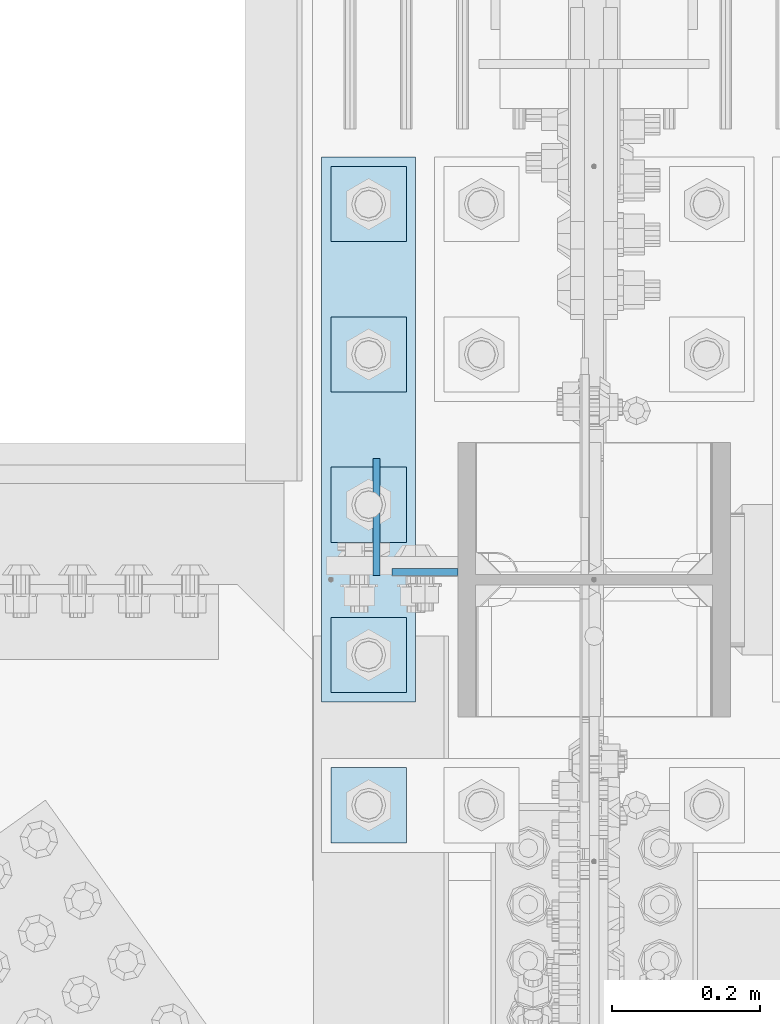
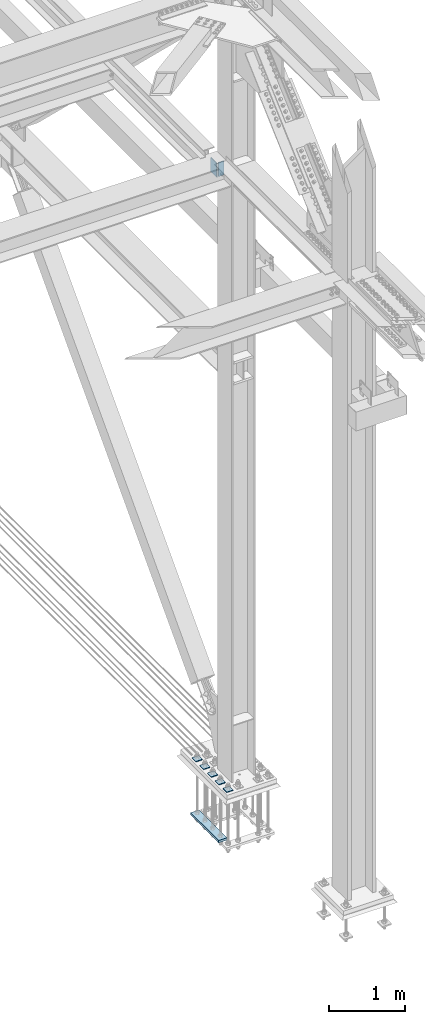
# One storey, part 3629 of 3843: 8 plates, 3 elements without a shape of their own.
"""IFC2X3 building model written with IfcOpenShell, lengths in millimetres."""

from ifc_helpers import new_model, si_unit, frame, origin_with_axes, place, context, subcontext, project, spatial, faceted_brep, material, type_object, element, aggregate, save


model = new_model("IFC2X3")

# Units and contexts
model_context = context("Model", 3, precision=1e-05, world=origin_with_axes())
body_context = subcontext(model_context, "Body", "Model", "MODEL_VIEW")
ifc_project = project(units=[si_unit("LENGTHUNIT", "METRE", prefix="MILLI"), si_unit("AREAUNIT", "SQUARE_METRE"), si_unit("VOLUMEUNIT", "CUBIC_METRE"), si_unit("MASSUNIT", "GRAM", prefix="KILO"), si_unit("TIMEUNIT", "SECOND"), si_unit("PLANEANGLEUNIT", "RADIAN"), si_unit("SOLIDANGLEUNIT", "STERADIAN"), si_unit("THERMODYNAMICTEMPERATUREUNIT", "DEGREE_CELSIUS"), si_unit("LUMINOUSINTENSITYUNIT", "LUMEN")], contexts=[model_context])

# Site, building, storey
site_placement = place(None, origin_with_axes())
site = spatial("IfcSite", under=ifc_project, at=site_placement, CompositionType="ELEMENT")
building_placement = place(site_placement, origin_with_axes())
building = spatial("IfcBuilding", under=site, at=building_placement, Name="Undefined", CompositionType="ELEMENT")
storey_placement = place(building_placement, origin_with_axes())
storey = spatial("IfcBuildingStorey", under=building, at=storey_placement, Name="Undefined", CompositionType="ELEMENT", Elevation=0.0)

# Assembly, plate
assembly_1_placement = place(storey_placement, origin_with_axes())
assembly_1 = element("IfcElementAssembly", 1, at=assembly_1_placement, inside=storey, Name="COLUMN", AssemblyPlace="NOTDEFINED", PredefinedType="RIGID_FRAME")
ifc_material = material(Name="STEEL/A572-50")
plate_type_1 = type_object("IfcPlateType", PredefinedType="NOTDEFINED")
plate_1_placement = place(assembly_1_placement, frame((85464.65, 92225.01875, 39573.2), z_axis=(-1.0, 0.0, 0.0), x_axis=(0.0, 0.0, -1.0)))
plate_1 = element("IfcPlate", 2, at=plate_1_placement, type_object=plate_type_1, material=ifc_material, Name="PLATE", context=body_context, shape_type="Brep", body=[
    faceted_brep([(0.0, -4.76249999999709, 0.0), (0.0, -4.76249999999709, 88.9000015258789), (0.0, 4.76249999999709, 88.9000015258789), (0.0, 4.76249999999709, 0.0), (228.600006102781, -4.7625000004191, 88.9000015257589), (228.600006102781, 4.76249999954598, 88.9000015257443), (228.600006103079, -4.7625000004482, 7.27595761418343e-12), (228.600006103079, 4.76249999954598, -7.27595761418343e-12)], [[[0, 1, 2, 3]], [[1, 4, 5, 2]], [[4, 6, 7, 5]], [[6, 0, 3, 7]], [[5, 7, 3, 2]], [[6, 4, 1, 0]]]),
])
aggregate(assembly_1, [plate_1])

# Assembly, plates
assembly_2_placement = place(storey_placement, origin_with_axes())
assembly_2 = element("IfcElementAssembly", 3, at=assembly_2_placement, inside=storey, Name="TEMPLATE", AssemblyPlace="NOTDEFINED", PredefinedType="RIGID_FRAME")
plate_type_2 = type_object("IfcPlateType", PredefinedType="NOTDEFINED")
plate_2_placement = place(assembly_2_placement, frame((85293.2, 91960.7, 29686.25), z_axis=(0.0, -1.0, 0.0), x_axis=(1.0, 0.0, 0.0)))
plate_2 = element("IfcPlate", 4, at=plate_2_placement, type_object=plate_type_2, material=ifc_material, Name="Washer Plate", context=body_context, shape_type="Brep", body=[
    faceted_brep([(0.0, -6.3499999046162, 0.0), (-1.67347025126219e-10, -6.35000000000582, 101.600000000151), (-1.67347025126219e-10, 6.35000000000582, 101.600000000151), (7.27595761418343e-12, 6.3499999046162, 0.0), (101.599998474121, -6.34999999999854, 101.599998474121), (101.599998474121, 6.34999999999854, 101.599998474121), (101.6, -6.34999999999854, 0.0), (101.6, 6.34999999999854, 0.0)], [[[0, 1, 2, 3]], [[1, 4, 5, 2]], [[4, 6, 7, 5]], [[6, 0, 3, 7]], [[5, 7, 3, 2]], [[6, 4, 1, 0]]]),
])
plate_3_placement = place(assembly_2_placement, frame((85293.2, 92163.9, 29686.25), z_axis=(0.0, -1.0, 0.0), x_axis=(1.0, 0.0, 0.0)))
plate_3 = element("IfcPlate", 5, at=plate_3_placement, type_object=plate_type_2, material=ifc_material, Name="Washer Plate", context=body_context, shape_type="Brep", body=[
    faceted_brep([(0.0, -6.3499999046162, 0.0), (-1.67347025126219e-10, -6.35000000000582, 101.600000000151), (-1.67347025126219e-10, 6.35000000000582, 101.600000000151), (7.27595761418343e-12, 6.3499999046162, 0.0), (101.599998474121, -6.34999999999854, 101.599998474121), (101.599998474121, 6.34999999999854, 101.599998474121), (101.6, -6.34999999999854, 0.0), (101.6, 6.34999999999854, 0.0)], [[[0, 1, 2, 3]], [[1, 4, 5, 2]], [[4, 6, 7, 5]], [[6, 0, 3, 7]], [[5, 7, 3, 2]], [[6, 4, 1, 0]]]),
])
plate_4_placement = place(assembly_2_placement, frame((85293.2, 92367.1, 29686.25), z_axis=(0.0, -1.0, 0.0), x_axis=(1.0, 0.0, 0.0)))
plate_4 = element("IfcPlate", 6, at=plate_4_placement, type_object=plate_type_2, material=ifc_material, Name="Washer Plate", context=body_context, shape_type="Brep", body=[
    faceted_brep([(0.0, -6.3499999046162, 0.0), (-1.67347025126219e-10, -6.35000000000582, 101.600000000151), (-1.67347025126219e-10, 6.35000000000582, 101.600000000151), (7.27595761418343e-12, 6.3499999046162, 0.0), (101.599998474121, -6.34999999999854, 101.599998474121), (101.599998474121, 6.34999999999854, 101.599998474121), (101.6, -6.34999999999854, 0.0), (101.6, 6.34999999999854, 0.0)], [[[0, 1, 2, 3]], [[1, 4, 5, 2]], [[4, 6, 7, 5]], [[6, 0, 3, 7]], [[5, 7, 3, 2]], [[6, 4, 1, 0]]]),
])
plate_5_placement = place(assembly_2_placement, frame((85293.2, 92570.3, 29686.25), z_axis=(0.0, -1.0, 0.0), x_axis=(1.0, 0.0, 0.0)))
plate_5 = element("IfcPlate", 7, at=plate_5_placement, type_object=plate_type_2, material=ifc_material, Name="Washer Plate", context=body_context, shape_type="Brep", body=[
    faceted_brep([(0.0, -6.3499999046162, 0.0), (-1.67347025126219e-10, -6.35000000000582, 101.600000000151), (-1.67347025126219e-10, 6.35000000000582, 101.600000000151), (7.27595761418343e-12, 6.3499999046162, 0.0), (101.599998474121, -6.34999999999854, 101.599998474121), (101.599998474121, 6.34999999999854, 101.599998474121), (101.6, -6.34999999999854, 0.0), (101.6, 6.34999999999854, 0.0)], [[[0, 1, 2, 3]], [[1, 4, 5, 2]], [[4, 6, 7, 5]], [[6, 0, 3, 7]], [[5, 7, 3, 2]], [[6, 4, 1, 0]]]),
])
plate_6_placement = place(assembly_2_placement, frame((85293.2, 92773.5, 29686.25), z_axis=(0.0, -1.0, 0.0), x_axis=(1.0, 0.0, 0.0)))
plate_6 = element("IfcPlate", 8, at=plate_6_placement, type_object=plate_type_2, material=ifc_material, Name="Washer Plate", context=body_context, shape_type="Brep", body=[
    faceted_brep([(0.0, -6.3499999046162, 0.0), (-1.67347025126219e-10, -6.35000000000582, 101.600000000151), (-1.67347025126219e-10, 6.35000000000582, 101.600000000151), (7.27595761418343e-12, 6.3499999046162, 0.0), (101.599998474121, -6.34999999999854, 101.599998474121), (101.599998474121, 6.34999999999854, 101.599998474121), (101.6, -6.34999999999854, 0.0), (101.6, 6.34999999999854, 0.0)], [[[0, 1, 2, 3]], [[1, 4, 5, 2]], [[4, 6, 7, 5]], [[6, 0, 3, 7]], [[5, 7, 3, 2]], [[6, 4, 1, 0]]]),
])

# Assembly, plate
assembly_3_placement = place(storey_placement, origin_with_axes())
assembly_3 = element("IfcElementAssembly", 9, at=assembly_3_placement, inside=storey, Name="BEAM", AssemblyPlace="NOTDEFINED", PredefinedType="RIGID_FRAME")
plate_type_3 = type_object("IfcPlateType", PredefinedType="NOTDEFINED")
plate_7_placement = place(assembly_3_placement, frame((85354.31875, 92220.25625, 39570.025), z_axis=(0.0, 1.0, 0.0), x_axis=(0.0, 0.0, -1.0)))
plate_7 = element("IfcPlate", 10, at=plate_7_placement, type_object=plate_type_3, material=ifc_material, Name="PLATE", context=body_context, shape_type="Brep", body=[
    faceted_brep([(0.0, -4.76249999999709, 0.0), (0.0, -4.76249999999709, 158.749999526888), (0.0, 4.76249999999709, 158.749999526888), (0.0, 4.76249999999709, 0.0), (228.599999999999, -4.76249999999709, 158.749999526888), (228.599999999999, 4.76249999999709, 158.749999526888), (228.600006103079, -4.7625000004482, 7.27595761418343e-12), (228.600006103079, 4.76249999954598, -7.27595761418343e-12)], [[[0, 1, 2, 3]], [[1, 4, 5, 2]], [[4, 6, 7, 5]], [[6, 0, 3, 7]], [[5, 7, 3, 2]], [[6, 4, 1, 0]]]),
])
aggregate(assembly_3, [plate_7])

# Plate
plate_type_4 = type_object("IfcPlateType", PredefinedType="NOTDEFINED")
plate_8_placement = place(assembly_2_placement, frame((85280.5, 92786.2, 28784.55), z_axis=(0.0, -1.0, 0.0), x_axis=(1.0, 0.0, 0.0)))
plate_8 = element("IfcPlate", 11, at=plate_8_placement, type_object=plate_type_4, material=ifc_material, Name="PLATE", context=body_context, shape_type="Brep", body=[
    faceted_brep([(0.0, -19.0500000000029, 0.0), (0.0, -19.0499999999993, 736.600036621094), (0.0, 19.0499999999993, 736.600036621094), (0.0, 19.0500000000029, 0.0), (127.0, -19.0499999999993, 736.600036621094), (127.0, 19.0499999999993, 736.600036621094), (127.0, -19.0499999999993, 0.0), (127.0, 19.0499999999993, 0.0)], [[[0, 1, 2, 3]], [[1, 4, 5, 2]], [[4, 6, 7, 5]], [[6, 0, 3, 7]], [[5, 7, 3, 2]], [[6, 4, 1, 0]]]),
])

aggregate(assembly_2, [plate_8, plate_2, plate_3, plate_4, plate_5, plate_6])

save(model, "model.ifc")
